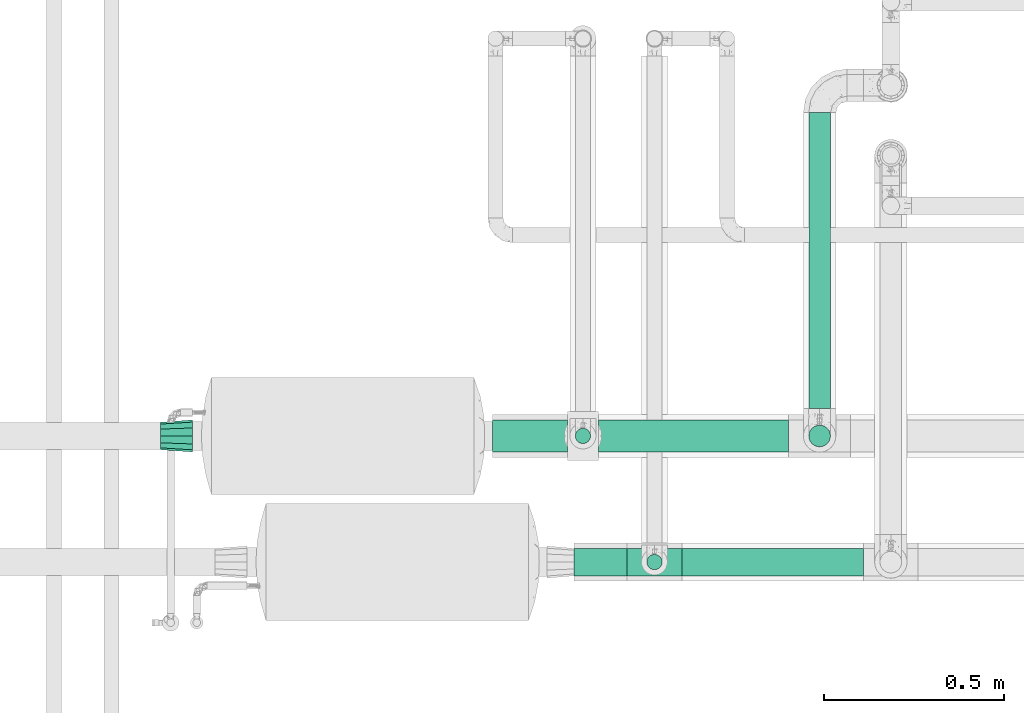
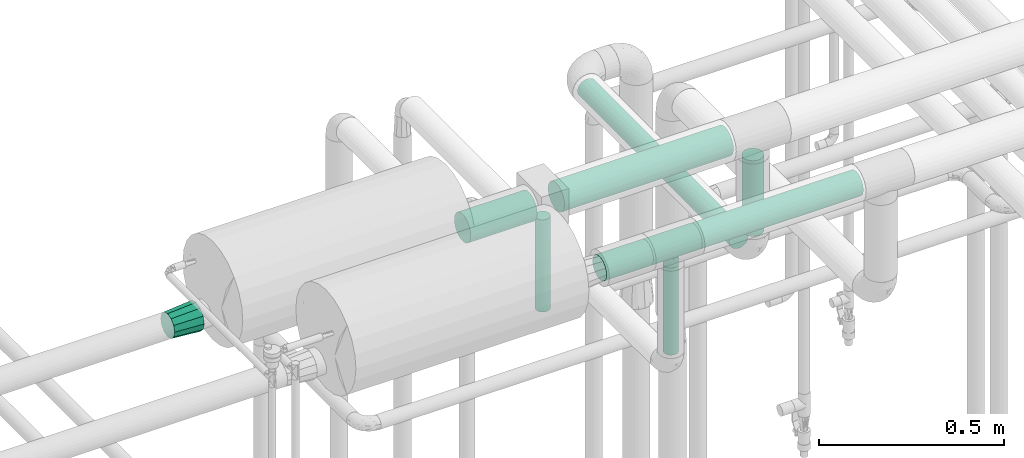
# One storey, part 571 of 827: 8 flow segments, 2 flow fittings.
"""IFC2X3 building model written with IfcOpenShell, lengths in millimetres."""

from ifc_helpers import new_model, entity, si_unit, converted_unit, derived_unit, direction, frame, origin, origin_2d_with_axis, place, context, subcontext, project, spatial, polyline, circle, outline, extrude, faceted_brep, source, transform, mapped, material, type_object, type_shapes, element, save


model = new_model("IFC2X3")

# Units and contexts
model_context = context("Model", 3, precision=0.01, world=origin(), true_north=direction((6.12303176911189e-17, 1.0)))
body_context = subcontext(model_context, "Body", "Model", "MODEL_VIEW")
ifc_project = project(units=[si_unit("LENGTHUNIT", "METRE", prefix="MILLI"), si_unit("AREAUNIT", "SQUARE_METRE"), si_unit("VOLUMEUNIT", "CUBIC_METRE"), converted_unit("PLANEANGLEUNIT", "DEGREE", entity("IfcRatioMeasure", 0.0174532925199433), si_unit("PLANEANGLEUNIT", "RADIAN"), dimensions=[0, 0, 0, 0, 0, 0, 0]), si_unit("MASSUNIT", "GRAM", prefix="KILO"), derived_unit("MASSDENSITYUNIT", [(si_unit("MASSUNIT", "GRAM", prefix="KILO"), 1), (si_unit("LENGTHUNIT", "METRE"), -3)]), derived_unit("MOMENTOFINERTIAUNIT", [(si_unit("LENGTHUNIT", "METRE"), 4)]), si_unit("TIMEUNIT", "SECOND"), si_unit("FREQUENCYUNIT", "HERTZ"), si_unit("THERMODYNAMICTEMPERATUREUNIT", "DEGREE_CELSIUS"), derived_unit("THERMALTRANSMITTANCEUNIT", [(si_unit("MASSUNIT", "GRAM", prefix="KILO"), 1), (si_unit("THERMODYNAMICTEMPERATUREUNIT", "KELVIN"), -1), (si_unit("TIMEUNIT", "SECOND"), -3)]), derived_unit("VOLUMETRICFLOWRATEUNIT", [(si_unit("LENGTHUNIT", "METRE"), 3), (si_unit("TIMEUNIT", "SECOND"), -1)]), derived_unit("MASSFLOWRATEUNIT", [(si_unit("MASSUNIT", "GRAM", prefix="KILO"), 1), (si_unit("TIMEUNIT", "SECOND"), -1)]), derived_unit("ROTATIONALFREQUENCYUNIT", [(si_unit("TIMEUNIT", "SECOND"), -1)]), si_unit("ELECTRICCURRENTUNIT", "AMPERE"), si_unit("ELECTRICVOLTAGEUNIT", "VOLT"), si_unit("POWERUNIT", "WATT"), si_unit("FORCEUNIT", "NEWTON", prefix="KILO"), si_unit("ILLUMINANCEUNIT", "LUX"), si_unit("LUMINOUSFLUXUNIT", "LUMEN"), si_unit("LUMINOUSINTENSITYUNIT", "CANDELA"), derived_unit("USERDEFINED", [(si_unit("MASSUNIT", "GRAM", prefix="KILO"), -1), (si_unit("LENGTHUNIT", "METRE"), -2), (si_unit("TIMEUNIT", "SECOND"), 3), (si_unit("LUMINOUSFLUXUNIT", "LUMEN"), 1)]), derived_unit("LINEARVELOCITYUNIT", [(si_unit("LENGTHUNIT", "METRE"), 1), (si_unit("TIMEUNIT", "SECOND"), -1)]), si_unit("PRESSUREUNIT", "PASCAL"), derived_unit("USERDEFINED", [(si_unit("LENGTHUNIT", "METRE"), -2), (si_unit("MASSUNIT", "GRAM", prefix="KILO"), 1), (si_unit("TIMEUNIT", "SECOND"), -2)]), derived_unit("LINEARFORCEUNIT", [(si_unit("MASSUNIT", "GRAM", prefix="KILO"), 1), (si_unit("LENGTHUNIT", "METRE"), 1), (si_unit("TIMEUNIT", "SECOND"), -2), (si_unit("LENGTHUNIT", "METRE"), -1)]), derived_unit("PLANARFORCEUNIT", [(si_unit("MASSUNIT", "GRAM", prefix="KILO"), 1), (si_unit("LENGTHUNIT", "METRE"), 1), (si_unit("TIMEUNIT", "SECOND"), -2), (si_unit("LENGTHUNIT", "METRE"), -2)])], contexts=[model_context])

# Site, building, storey
site_placement = place(None, origin())
site = spatial("IfcSite", under=ifc_project, at=site_placement, CompositionType="ELEMENT")
building_placement = place(site_placement, origin())
building = spatial("IfcBuilding", under=site, at=building_placement, CompositionType="ELEMENT")
storey_placement = place(building_placement, frame((0.0, 0.0, 28200.0)))
storey = spatial("IfcBuildingStorey", under=building, at=storey_placement, Name="08", CompositionType="ELEMENT", Elevation=28200.0)

# Flow segments
pipe_segment_type_1 = type_object("IfcPipeSegmentType", PredefinedType="NOTDEFINED")
flow_segment_1_placement = place(storey_placement, frame((17044.26, 14360.4, 2760.39)))
element("IfcFlowSegment", 1, at=flow_segment_1_placement, inside=storey, type_object=pipe_segment_type_1, context=body_context, shape_type="SweptSolid", body=[
    extrude(circle(Radius=38.0, at=origin_2d_with_axis()), frame((0.0, 39.6, 39.6), z_axis=(1.0, 0.0, 0.0), x_axis=(0.0, 1.0, 0.0)), (0.0, 0.0, 1.0), 146.451640100535),
])
flow_segment_2_placement = place(storey_placement, frame((17342.71, 14360.4, 2760.39)))
element("IfcFlowSegment", 2, at=flow_segment_2_placement, inside=storey, type_object=pipe_segment_type_1, context=body_context, shape_type="SweptSolid", body=[
    extrude(outline(polyline([(-4.96, -37.67), (4.96, -37.67), (14.54, -35.11), (23.13, -30.15), (30.15, -23.13), (35.11, -14.54), (37.67, -4.96), (37.67, 4.96), (35.11, 14.54), (30.15, 23.13), (23.13, 30.15), (14.54, 35.11), (4.96, 37.67), (-4.96, 37.67), (-14.54, 35.11), (-23.13, 30.15), (-30.15, 23.13), (-35.11, 14.54), (-37.67, 4.96), (-37.67, -4.96), (-35.11, -14.54), (-30.15, -23.13), (-23.13, -30.15), (-14.54, -35.11), (-4.96, -37.67)])), frame((0.0, 39.6, 39.6), z_axis=(1.0, -2.72219389870259e-09, 0.0), x_axis=(0.0, -0.130526192219997, 0.991444861373818)), (0.0, 0.0, 1.0), 503.577868480491),
])
flow_segment_3_placement = place(storey_placement, frame((16817.99, 14703.7, 2753.9)))
element("IfcFlowSegment", 3, at=flow_segment_3_placement, inside=storey, type_object=pipe_segment_type_1, context=body_context, shape_type="SweptSolid", body=[
    extrude(circle(Radius=44.5, at=origin_2d_with_axis()), frame((0.0, 46.1, 46.1), z_axis=(1.0, 0.0, 0.0), x_axis=(0.0, 1.0, 0.0)), (0.0, 0.0, 1.0), 207.871938328139),
])
flow_segment_4_placement = place(storey_placement, frame((17110.86, 14703.7, 2753.9)))
element("IfcFlowSegment", 4, at=flow_segment_4_placement, inside=storey, type_object=pipe_segment_type_1, context=body_context, shape_type="SweptSolid", body=[
    extrude(circle(Radius=44.5, at=origin_2d_with_axis()), frame((0.0, 46.1, 46.1), z_axis=(1.0, 0.0, 0.0), x_axis=(0.0, 1.0, 0.0)), (0.0, 0.0, 1.0), 527.878835292874),
])
pipe_segment_type_2 = type_object("IfcPipeSegmentType", PredefinedType="NOTDEFINED")
flow_segment_5_placement = place(storey_placement, frame((17693.15, 14825.77, 2366.72)))
element("IfcFlowSegment", 5, at=flow_segment_5_placement, inside=storey, type_object=pipe_segment_type_2, context=body_context, shape_type="SweptSolid", body=[
    extrude(circle(Radius=30.0, at=origin_2d_with_axis()), frame((31.6, 0.06, 31.6), z_axis=(0.0, 0.999997897844181, 0.00205044073797777), x_axis=(-1.0, 0.0, 0.0)), (0.0, 0.0, 1.0), 820.61184010721),
])
flow_segment_6_placement = place(storey_placement, frame((17243.97, 14377.25, 2448.0)))
element("IfcFlowSegment", 6, at=flow_segment_6_placement, inside=storey, type_object=pipe_segment_type_2, context=body_context, shape_type="SweptSolid", body=[
    extrude(circle(Radius=21.15, at=origin_2d_with_axis()), frame((22.75, 22.75, 0.0)), (0.0, 0.0, 1.0), 287.982896996913),
])
flow_segment_7_placement = place(storey_placement, frame((17693.15, 14718.08, 2474.32)))
element("IfcFlowSegment", 7, at=flow_segment_7_placement, inside=storey, type_object=pipe_segment_type_2, context=body_context, shape_type="SweptSolid", body=[
    extrude(circle(Radius=30.0, at=origin_2d_with_axis()), frame((31.6, 31.6, 0.0)), (0.0, 0.0, 1.0), 249.679641729304),
])
flow_segment_8_placement = place(storey_placement, frame((17045.62, 14727.05, 2448.0)))
element("IfcFlowSegment", 8, at=flow_segment_8_placement, inside=storey, type_object=pipe_segment_type_2, context=body_context, shape_type="SweptSolid", body=[
    extrude(circle(Radius=21.15, at=origin_2d_with_axis()), frame((22.75, 22.75, 0.0)), (0.0, 0.0, 1.0), 304.500000000017),
])

# Flow fittings
ifc_material = material()
pipe_fitting_type_1 = type_object("IfcPipeFittingType", Name="ADSK_1", PredefinedType="NOTDEFINED", material=ifc_material)
shared_shape_1 = source(origin(), body_context, "Body", "Brep", [
    faceted_brep([(-76.0, 9.85, -36.75), (-76.0, 0.0, -38.05), (-76.0, -9.85, -36.75), (-76.0, -19.03, -32.95), (-76.0, -26.91, -26.91), (-76.0, -32.95, -19.03), (-76.0, -36.75, -9.85), (-76.0, -38.05, 0.0), (-76.0, -36.75, 9.85), (-76.0, -32.95, 19.02), (-76.0, -26.91, 26.91), (-76.0, -19.03, 32.95), (-76.0, -9.85, 36.75), (-76.0, 0.0, 38.05), (-76.0, 9.85, 36.75), (-76.0, 19.02, 32.95), (-76.0, 26.91, 26.91), (-76.0, 32.95, 19.02), (-76.0, 36.75, 9.85), (-76.0, 38.05, 0.0), (-76.0, 36.75, -9.85), (-76.0, 32.95, -19.03), (-76.0, 26.91, -26.91), (-76.0, 19.02, -32.95), (76.0, 26.91, -26.91), (76.0, 32.95, -19.03), (76.0, 36.75, -9.85), (76.0, 38.05, 0.0), (76.0, 36.75, 9.85), (76.0, 32.95, 19.02), (76.0, 26.91, 26.91), (76.0, 19.02, 32.95), (76.0, 9.85, 36.75), (76.0, 0.0, 38.05), (76.0, -9.85, 36.75), (76.0, -19.03, 32.95), (76.0, -26.91, 26.91), (76.0, -32.95, 19.02), (76.0, -36.75, 9.85), (76.0, -38.05, 0.0), (76.0, -36.75, -9.85), (76.0, -32.95, -19.03), (76.0, -26.91, -26.91), (76.0, -19.03, -32.95), (76.0, -9.85, -36.75), (76.0, 0.0, -38.05), (76.0, 9.85, -36.75), (76.0, 19.02, -32.95), (19.88, -37.33, 7.37), (20.54, -37.69, 3.68), (21.2, -38.05, 0.0), (16.2, -35.51, 13.68), (3.75, -31.82, 20.87), (10.67, -33.35, 18.32), (7.21, -32.58, 19.59), (-21.2, -38.05, 0.0), (-20.54, -37.69, 3.68), (-19.88, -37.33, 7.37), (-16.2, -35.51, 13.67), (-10.67, -33.35, 18.32), (-7.22, -32.59, 19.59), (-3.76, -31.82, 20.86), (0.0, -31.82, 20.86), (3.75, -31.82, -20.87), (10.67, -33.35, -18.32), (7.21, -32.58, -19.59), (16.2, -35.51, -13.68), (19.88, -37.33, -7.37), (20.54, -37.69, -3.68), (-3.76, -31.82, -20.86), (-7.22, -32.59, -19.59), (-10.67, -33.35, -18.32), (-16.2, -35.51, -13.67), (0.0, -31.82, -20.86), (-19.88, -37.33, -7.37), (-20.54, -37.69, -3.68), (0.0, -64.0, -21.2), (5.49, -64.0, -20.48), (10.6, -64.0, -18.36), (14.99, -64.0, -14.99), (18.36, -64.0, -10.6), (20.48, -64.0, -5.49), (21.2, -64.0, 0.0), (20.48, -64.0, 5.49), (18.36, -64.0, 10.6), (14.99, -64.0, 14.99), (10.6, -64.0, 18.36), (5.49, -64.0, 20.48), (0.0, -64.0, 21.2), (-5.49, -64.0, 20.48), (-10.6, -64.0, 18.36), (-14.99, -64.0, 14.99), (-18.36, -64.0, 10.6), (-20.48, -64.0, 5.49), (-21.2, -64.0, 0.0), (-20.48, -64.0, -5.49), (-18.36, -64.0, -10.6), (-14.99, -64.0, -14.99), (-10.6, -64.0, -18.36), (-5.49, -64.0, -20.48)], [[[0, 1, 2, 3, 4, 5, 6, 7, 8, 9, 10, 11, 12, 13, 14, 15, 16, 17, 18, 19, 20, 21, 22, 23]], [[24, 25, 26, 27, 28, 29, 30, 31, 32, 33, 34, 35, 36, 37, 38, 39, 40, 41, 42, 43, 44, 45, 46, 47]], [[39, 38, 48]], [[39, 48, 49, 50]], [[38, 51, 48]], [[37, 36, 52]], [[53, 51, 37]], [[37, 52, 54, 53]], [[36, 10, 52]], [[37, 51, 38]], [[7, 55, 56, 57]], [[8, 7, 57]], [[57, 58, 8]], [[9, 59, 60, 61]], [[59, 9, 58]], [[9, 61, 10]], [[58, 9, 8]], [[10, 61, 62, 52]], [[36, 35, 11, 10]], [[13, 12, 34, 33]], [[12, 11, 35, 34]], [[14, 13, 33, 32]], [[29, 28, 18, 17]], [[16, 15, 31, 30]], [[17, 16, 30, 29]], [[32, 31, 15, 14]], [[19, 18, 28, 27]], [[26, 25, 21, 20]], [[25, 24, 22, 21]], [[27, 26, 20, 19]], [[45, 44, 2, 1]], [[0, 23, 47, 46]], [[1, 0, 46, 45]], [[24, 47, 23, 22]], [[3, 2, 44, 43]], [[43, 42, 4, 3]], [[42, 41, 63]], [[41, 64, 65, 63]], [[41, 66, 64]], [[42, 63, 4]], [[40, 39, 67]], [[67, 66, 40]], [[39, 50, 68, 67]], [[40, 66, 41]], [[5, 69, 70, 71]], [[5, 4, 69]], [[71, 72, 5]], [[4, 63, 73, 69]], [[72, 74, 6]], [[74, 7, 6]], [[7, 74, 75, 55]], [[72, 6, 5]], [[76, 77, 78, 79, 80, 81, 82, 83, 84, 85, 86, 87, 88, 89, 90, 91, 92, 93, 94, 95, 96, 97, 98, 99]], [[93, 56, 94]], [[88, 61, 89]], [[60, 90, 89]], [[60, 59, 90]], [[93, 57, 56]], [[57, 93, 92]], [[49, 48, 83]], [[58, 92, 91]], [[56, 55, 94]], [[57, 92, 58]], [[86, 54, 87]], [[59, 58, 91]], [[89, 61, 60]], [[59, 91, 90]], [[88, 52, 62, 61]], [[86, 53, 54]], [[85, 53, 86]], [[48, 84, 83]], [[85, 84, 51]], [[52, 88, 87]], [[54, 52, 87]], [[53, 85, 51]], [[51, 84, 48]], [[82, 49, 83]], [[49, 82, 50]], [[81, 68, 82]], [[66, 80, 79]], [[75, 94, 55]], [[81, 67, 68]], [[80, 67, 81]], [[78, 64, 79]], [[68, 50, 82]], [[67, 80, 66]], [[77, 63, 65]], [[64, 66, 79]], [[76, 69, 73, 63]], [[98, 70, 99]], [[65, 64, 78]], [[98, 71, 70]], [[76, 63, 77]], [[75, 74, 95]], [[97, 71, 98]], [[74, 96, 95]], [[97, 96, 72]], [[69, 76, 99]], [[70, 69, 99]], [[71, 97, 72]], [[72, 96, 74]], [[94, 75, 95]], [[65, 78, 77]]]),
])
type_shapes(pipe_fitting_type_1, [shared_shape_1])
flow_fitting_1_placement = place(storey_placement, frame((17266.71, 14400.0, 2799.98), z_axis=(0.0, -1.0, 0.0), x_axis=(1.0, 0.0, 0.0)))
element("IfcFlowFitting", 9, at=flow_fitting_1_placement, inside=storey, type_object=pipe_fitting_type_1, material=ifc_material, Name="ADSK_1", ObjectType="ADSK_1", context=body_context, shape_type="MappedRepresentation", body=[
    mapped(shared_shape_1, transform((0.0, 0.0, 0.0), scale=1.0)),
])
pipe_fitting_type_2 = type_object("IfcPipeFittingType", Name="ADSK_1", PredefinedType="NOTDEFINED", material=ifc_material)
shared_shape_2 = source(origin(), body_context, "Body", "Brep", [
    faceted_brep([(89.0, -44.45, 0.0), (89.0, -41.96, -9.31), (89.0, -38.49, -22.22), (89.0, -30.36, -30.36), (89.0, -22.23, -38.49), (89.0, -11.11, -41.47), (89.0, 0.0, -44.45), (89.0, 11.11, -41.47), (89.0, 22.22, -38.49), (89.0, 30.36, -30.36), (89.0, 38.49, -22.22), (89.0, 41.96, -9.31), (89.0, 44.45, 0.0), (89.0, 41.96, 9.31), (89.0, 38.49, 22.23), (89.0, 30.36, 30.36), (89.0, 22.22, 38.49), (89.0, 11.11, 41.47), (89.0, 0.0, 44.45), (89.0, -11.11, 41.47), (89.0, -22.23, 38.49), (89.0, -30.36, 30.36), (89.0, -38.49, 22.23), (89.0, -41.96, 9.31), (0.0, 38.05, 0.0), (0.0, 35.5, -9.51), (0.0, 32.95, -19.02), (0.0, 25.99, -25.99), (0.0, 19.02, -32.95), (0.0, 9.51, -35.5), (0.0, 0.0, -38.05), (0.0, -9.51, -35.5), (0.0, -19.03, -32.95), (0.0, -25.99, -25.99), (0.0, -32.95, -19.02), (0.0, -35.5, -9.51), (0.0, -38.05, 0.0), (0.0, -35.5, 9.51), (0.0, -32.95, 19.03), (0.0, -25.99, 25.99), (0.0, -19.03, 32.95), (0.0, -9.51, 35.5), (0.0, 0.0, 38.05), (0.0, 9.51, 35.5), (0.0, 19.03, 32.95), (0.0, 25.99, 25.99), (0.0, 32.95, 19.03), (0.0, 35.5, 9.51)], [[[0, 1, 2, 3, 4, 5, 6, 7, 8, 9, 10, 11, 12, 13, 14, 15, 16, 17, 18, 19, 20, 21, 22, 23]], [[24, 25, 26, 27, 28, 29, 30, 31, 32, 33, 34, 35, 36, 37, 38, 39, 40, 41, 42, 43, 44, 45, 46, 47]], [[2, 1, 0, 36, 35, 34]], [[28, 8, 7, 6, 30, 29]], [[32, 4, 3, 2, 34, 33]], [[5, 4, 32, 31, 30, 6]], [[10, 26, 25, 24, 12, 11]], [[9, 8, 28, 27, 26, 10]], [[14, 13, 12, 24, 47, 46]], [[40, 20, 19, 18, 42, 41]], [[44, 16, 15, 14, 46, 45]], [[17, 16, 44, 43, 42, 18]], [[22, 38, 37, 36, 0, 23]], [[21, 20, 40, 39, 38, 22]]]),
])
type_shapes(pipe_fitting_type_2, [shared_shape_2])
flow_fitting_2_placement = place(storey_placement, frame((15896.99, 14749.8, 2800.0), z_axis=(0.0, 0.0, 1.0), x_axis=(0.999999993712363, -0.000112139528928064, 0.0)))
element("IfcFlowFitting", 10, at=flow_fitting_2_placement, inside=storey, type_object=pipe_fitting_type_2, material=ifc_material, Name="ADSK_1", ObjectType="ADSK_1", context=body_context, shape_type="MappedRepresentation", body=[
    mapped(shared_shape_2, transform((0.0, 0.0, 0.0), scale=1.0)),
])

save(model, "model.ifc")
